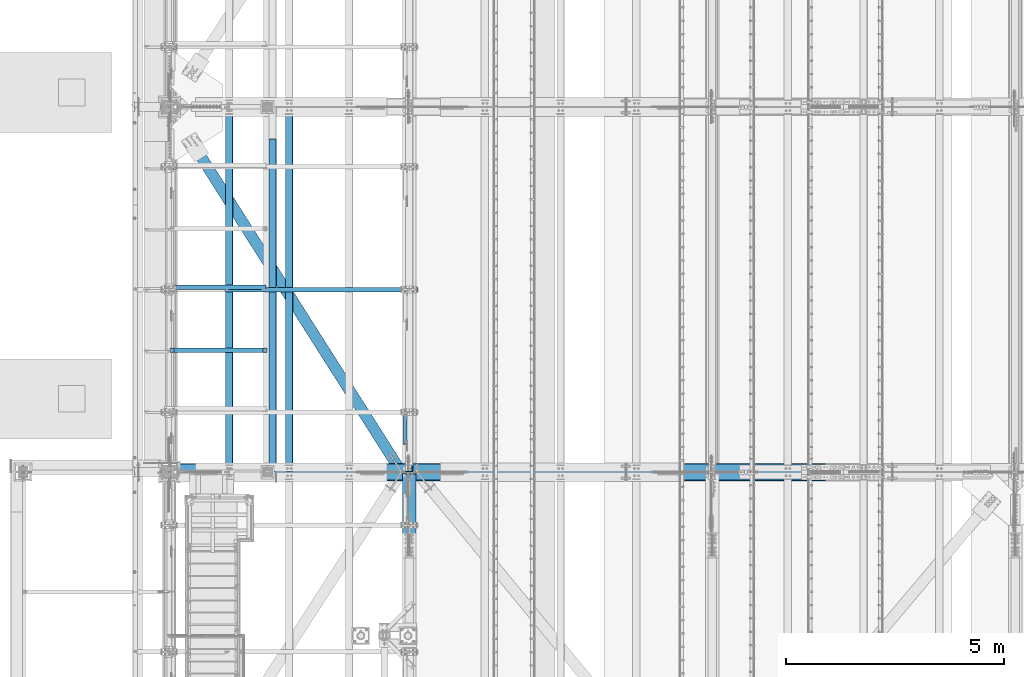
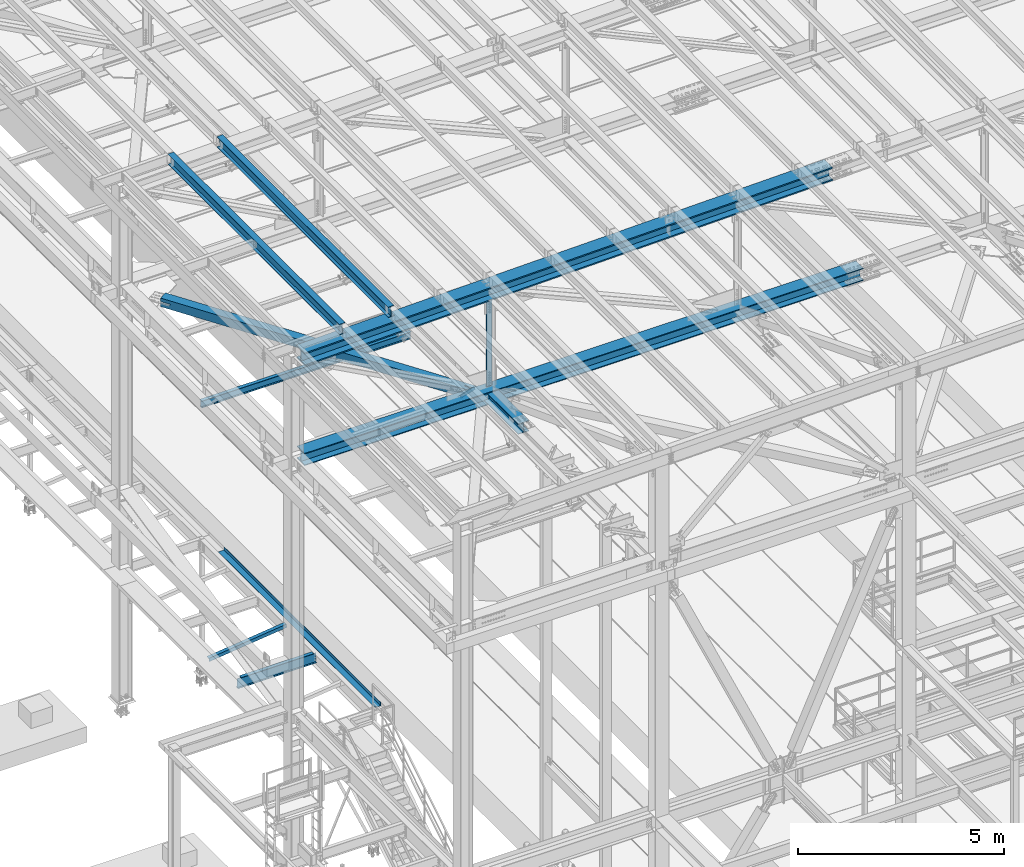
# One storey, part 1806 of 3843: 11 beams, 1 member, 11 elements without a shape of their own.
"""IFC2X3 building model written with IfcOpenShell, lengths in millimetres."""

from ifc_helpers import new_model, si_unit, frame, origin_with_axes, place, context, subcontext, project, spatial, faceted_brep, material, type_object, element, aggregate, save


model = new_model("IFC2X3")

# Units and contexts
model_context = context("Model", 3, precision=1e-05, world=origin_with_axes())
body_context = subcontext(model_context, "Body", "Model", "MODEL_VIEW")
ifc_project = project(units=[si_unit("LENGTHUNIT", "METRE", prefix="MILLI"), si_unit("AREAUNIT", "SQUARE_METRE"), si_unit("VOLUMEUNIT", "CUBIC_METRE"), si_unit("MASSUNIT", "GRAM", prefix="KILO"), si_unit("TIMEUNIT", "SECOND"), si_unit("PLANEANGLEUNIT", "RADIAN"), si_unit("SOLIDANGLEUNIT", "STERADIAN"), si_unit("THERMODYNAMICTEMPERATUREUNIT", "DEGREE_CELSIUS"), si_unit("LUMINOUSINTENSITYUNIT", "LUMEN")], contexts=[model_context])

# Site, building, storey
site_placement = place(None, origin_with_axes())
site = spatial("IfcSite", under=ifc_project, at=site_placement, CompositionType="ELEMENT")
building_placement = place(site_placement, origin_with_axes())
building = spatial("IfcBuilding", under=site, at=building_placement, Name="Undefined", CompositionType="ELEMENT")
storey_placement = place(building_placement, origin_with_axes())
storey = spatial("IfcBuildingStorey", under=building, at=storey_placement, Name="Undefined", CompositionType="ELEMENT", Elevation=0.0)

# Assembly, beam
assembly_1_placement = place(storey_placement, origin_with_axes())
assembly_1 = element("IfcElementAssembly", 1, at=assembly_1_placement, inside=storey, Name="ANGLE", AssemblyPlace="NOTDEFINED", PredefinedType="RIGID_FRAME")
ifc_material_1 = material(Name="STEEL/A572-50")
beam_type_1 = type_object("IfcBeamType", Name="L4X4X3/8", PredefinedType="NOTDEFINED")
beam_1_placement = place(assembly_1_placement, frame((38788.5093206542, 38077.874218, 33960.1419503901), z_axis=(0.0, 1.0, 0.0), x_axis=(-0.993268693078032, 0.0, -0.115833084009098)))
beam_1 = element("IfcBeam", 2, at=beam_1_placement, type_object=beam_type_1, material=ifc_material_1, Name="ANGLE", ObjectType="L4X4X3/8", context=body_context, shape_type="Brep", body=[
    faceted_brep([(0.0, 50.8000000000029, -50.8000000000029), (0.0, 50.8000000000029, 50.8000000000029), (2192.8104802954, 50.7999999940694, 50.8000000000029), (2192.8104802954, 50.7999999940694, -50.8000000000029), (0.0, 41.2750000000015, 50.8000000000029), (2192.81048029537, 41.2749999940788, 50.8000000000029), (0.0, 41.2749999999942, -41.2750000000015), (2192.81048029537, 41.2749999940788, -41.2750000000015), (0.0, -50.8000000000029, -41.2750000000015), (2192.81048029512, -50.8000000058528, -41.2750000000015), (0.0, -50.8000000000029, -50.8000000000029), (2192.81048029512, -50.8000000058528, -50.8000000000029)], [[[0, 1, 2, 3]], [[1, 4, 5, 2]], [[4, 6, 7, 5]], [[6, 8, 9, 7]], [[8, 10, 11, 9]], [[10, 0, 3, 11]], [[5, 7, 9, 11, 3, 2]], [[10, 8, 6, 4, 1, 0]]]),
])
aggregate(assembly_1, [beam_1])

assembly_2_placement = place(storey_placement, origin_with_axes())
assembly_2 = element("IfcElementAssembly", 3, at=assembly_2_placement, inside=storey, Name="BEAM", AssemblyPlace="NOTDEFINED", PredefinedType="RIGID_FRAME")
ifc_material_2 = material(Name="STEEL/A992")
beam_type_2 = type_object("IfcBeamType", Name="W12X26", PredefinedType="NOTDEFINED")
beam_2_placement = place(assembly_2_placement, frame((39315.909262284, 33845.2697323849, 45633.2759905987), z_axis=(-0.0211520981862632, -0.00148010699961742, 0.99977517373937), x_axis=(0.0, 0.999998904151063, 0.00148043800022374)))
beam_2 = element("IfcBeam", 4, at=beam_2_placement, type_object=beam_type_2, material=ifc_material_2, Name="BEAM", ObjectType="W12X26", context=body_context, shape_type="Brep", body=[
    faceted_brep([(12.6974689719063, 82.5500000000684, -155.575000000084), (12.7115269488204, 82.5499999999593, -146.050000000228), (8343.92065673555, 82.5500000005122, -146.050000026378), (8343.90655870306, 82.5500000005268, -155.575000026394), (12.7140125297374, 3.17500000011205, -146.050000000425), (8343.92314231647, 3.17500000066502, -146.050000026575), (13.1463521932747, 3.17499999986467, 146.050000000359), (8344.35548198001, 3.17500000041036, 146.049999974217), (13.1438666123577, 82.5499999997046, 146.050000000556), (8344.35299639909, 82.5500000002576, 146.049999974406), (13.157964644859, 82.5499999996973, 155.575000000586), (8344.3670944316, 82.5500000002503, 155.574999974437), (13.1631346531794, -82.5499999999738, 155.575000000172), (8344.37226443992, -82.5499999994208, 155.574999974022), (13.1490366206708, -82.5499999999665, 146.050000000148), (8344.35816640741, -82.5499999994136, 146.049999973999), (13.1465510397466, -3.17500000011933, 146.050000000345), (8344.35568082648, -3.17499999956635, 146.049999974195), (12.7142113762093, -3.17499999986467, -146.050000000439), (8343.92334116295, -3.17499999931169, -146.050000026589), (12.7166969571335, -82.5499999997119, -146.050000000636), (8343.92582674388, -82.5499999991589, -146.050000026778), (12.7025580552727, -82.54999999961, -155.575000000543), (8343.91172871137, -82.5499999991516, -155.575000026802)], [[[0, 1, 2, 3]], [[1, 4, 5, 2]], [[4, 6, 7, 5]], [[6, 8, 9, 7]], [[8, 10, 11, 9]], [[10, 12, 13, 11]], [[12, 14, 15, 13]], [[14, 16, 17, 15]], [[16, 18, 19, 17]], [[18, 20, 21, 19]], [[20, 22, 23, 21]], [[22, 0, 3, 23]], [[5, 7, 9, 11, 13, 15, 17, 19, 21, 23, 3, 2]], [[22, 20, 18, 16, 14, 12, 10, 8, 6, 4, 1, 0]]]),
])
aggregate(assembly_2, [beam_2])

assembly_3_placement = place(storey_placement, origin_with_axes())
assembly_3 = element("IfcElementAssembly", 5, at=assembly_3_placement, inside=storey, Name="BEAM", AssemblyPlace="NOTDEFINED", PredefinedType="RIGID_FRAME")
beam_3_placement = place(assembly_3_placement, frame((37944.3092622946, 33845.3818949881, 45603.5956322492), z_axis=(-0.0211520981049397, -0.000759152000093307, 0.999775981124772), x_axis=(0.0, 0.999999711715768, 0.000759320999784055)))
beam_3 = element("IfcBeam", 6, at=beam_3_placement, type_object=beam_type_2, material=ifc_material_2, Name="BEAM", ObjectType="W12X26", context=body_context, shape_type="Brep", body=[
    faceted_brep([(12.698677882734, 82.5500000001193, -155.575000000288), (12.7059087992311, 82.550000000112, -146.050000000258), (8343.90831061216, 82.5499999995445, -146.049999973598), (8343.9011105949, 82.5499999798194, -155.575000016506), (12.7071836598843, 3.17500000025029, -146.050000000352), (8343.90958547281, 3.17499999968277, -146.049999973678), (12.9289317657676, 3.17499999975553, 146.050000000454), (8344.1313335787, 3.174999999188, 146.05000002712), (12.9276569051217, 82.54999999961, 146.050000000534), (8344.13005871805, 82.5499999990425, 146.0500000272), (12.9348878216188, 82.5499999995955, 155.575000000557), (8344.13728963455, 82.5499999990352, 155.575000027224), (12.9375395317693, -82.550000000112, 155.57500000039), (8344.13994134469, -82.5500000006796, 155.575000027056), (12.9303086152722, -82.5500000000902, 146.050000000359), (8344.1327104282, -82.5500000006577, 146.050000027026), (12.929033754619, -3.17500000023574, 146.050000000447), (8344.13143556755, -3.17500000080327, 146.050000027106), (12.7072856487284, -3.17499999974098, -146.050000000352), (8343.90968746167, -3.1750000003085, -146.049999973686), (12.7085605093816, -82.5499999995955, -146.050000000432), (8343.91096232231, -82.550000000163, -146.049999973773), (12.7013295928846, -82.5499999995809, -155.575000000463), (8343.90373140582, -82.5500000001484, -155.574999973804)], [[[0, 1, 2, 3]], [[1, 4, 5, 2]], [[4, 6, 7, 5]], [[6, 8, 9, 7]], [[8, 10, 11, 9]], [[10, 12, 13, 11]], [[12, 14, 15, 13]], [[14, 16, 17, 15]], [[16, 18, 19, 17]], [[18, 20, 21, 19]], [[20, 22, 23, 21]], [[22, 0, 3, 23]], [[5, 7, 9, 11, 13, 15, 17, 19, 21, 23, 3, 2]], [[22, 20, 18, 16, 14, 12, 10, 8, 6, 4, 1, 0]]]),
])
aggregate(assembly_3, [beam_3])

assembly_4_placement = place(storey_placement, origin_with_axes())
assembly_4 = element("IfcElementAssembly", 7, at=assembly_4_placement, inside=storey, Name="BEAM", AssemblyPlace="NOTDEFINED", PredefinedType="RIGID_FRAME")
ifc_material_3 = material(Name="STEEL/A36")
beam_type_3 = type_object("IfcBeamType", PredefinedType="NOTDEFINED")
beam_4_placement = place(assembly_4_placement, frame((38858.825, 37661.85, 34039.175), z_axis=(0.0, -1.0, 0.0), x_axis=(1.0, 0.0, 0.0)))
beam_4 = element("IfcBeam", 8, at=beam_4_placement, type_object=beam_type_3, material=ifc_material_3, Name="BENT_PLATE", context=body_context, shape_type="Brep", body=[
    faceted_brep([(25.3999999999942, -3.17500000000291, 3752.84999999999), (25.3999999999942, 3.17500000000291, 3752.84999999999), (0.0, 3.17500000000291, 3752.84999999999), (0.0, -3.17500000000291, 3752.84999999999), (25.400000000016, -3.17500000000291, 3810.00000000001), (25.400000000016, 3.17500000000291, 3810.0), (165.100006103516, -3.17500000000291, -3810.0), (0.0, -3.17500000000291, -3810.0), (0.0, 3.17500000000291, -3810.0), (158.750005722046, 3.17500000000291, -3810.0), (158.749999999993, 98.4249996185172, -3810.0), (165.099999999999, 98.4249999999811, -3810.0), (158.750005722046, 3.17500000000291, 3810.0), (158.749999999993, 98.4249996185172, 3810.0), (165.099999999999, 98.4249999999811, 3810.0), (165.100006103516, -3.17500000000291, 3810.0)], [[[0, 1, 2, 3]], [[4, 5, 1, 0]], [[6, 7, 8, 9, 10, 11]], [[9, 12, 13, 10]], [[14, 11, 10, 13]], [[15, 6, 11, 14]], [[3, 7, 6, 15, 4, 0]], [[8, 7, 3, 2]], [[12, 9, 8, 2, 1, 5]], [[15, 14, 13, 12, 5, 4]]]),
])
aggregate(assembly_4, [beam_4])

# Assembly, member
assembly_5_placement = place(storey_placement, origin_with_axes())
assembly_5 = element("IfcElementAssembly", 9, at=assembly_5_placement, inside=storey, Name="ANGLE", AssemblyPlace="NOTDEFINED", PredefinedType="RIGID_FRAME")
member_type = type_object("IfcMemberType", Name="L3X3X1/4", PredefinedType="NOTDEFINED")
member_placement = place(assembly_5_placement, frame((41973.5, 34262.8635145216, 42254.6364854784), z_axis=(0.0, -0.707106781186548, -0.707106781186548), x_axis=(5.70000238222118e-08, 0.707106781186546, -0.707106781186546)))
member = element("IfcMember", 10, at=member_placement, type_object=member_type, material=ifc_material_1, Name="ANGLE", ObjectType="L3X3X1/4", context=body_context, shape_type="Brep", body=[
    faceted_brep([(1266.4928988076, -38.0999999999985, -31.7499999999272), (1266.4928988076, -38.0999999999985, -38.0999999999112), (1266.4928988076, 38.0999999999985, -38.0999999999112), (1266.49289880759, 38.0999999999985, 38.099999999904), (1266.49289880759, 31.75, 38.099999999904), (1266.4928988076, 31.75, -31.7499999999272), (275.8928988077, 31.75, 38.0999999998967), (275.892898807697, 31.75, -31.7499999999272), (275.892898807697, -38.0999999999985, -31.7499999999272), (275.8928988077, -38.0999999999985, -38.0999999999185), (275.8928988077, 38.0999999999985, -38.0999999999185), (275.8928988077, 38.0999999999985, 38.0999999998967)], [[[0, 1, 2, 3, 4, 5]], [[5, 4, 6, 7]], [[0, 5, 7, 8]], [[1, 0, 8, 9]], [[2, 1, 9, 10]], [[3, 2, 10, 11]], [[4, 3, 11, 6]], [[10, 9, 8, 7, 6, 11]]]),
])
aggregate(assembly_5, [member])

# Assembly, beam
assembly_6_placement = place(storey_placement, origin_with_axes())
assembly_6 = element("IfcElementAssembly", 11, at=assembly_6_placement, inside=storey, Name="BEAM", AssemblyPlace="NOTDEFINED", PredefinedType="RIGID_FRAME")
beam_type_4 = type_object("IfcBeamType", Name="W8X13", PredefinedType="NOTDEFINED")
beam_5_placement = place(assembly_6_placement, frame((36372.8, 38023.8, 41402.0), z_axis=(0.0, 0.0, 1.0), x_axis=(1.0, 0.0, 0.0)))
beam_5 = element("IfcBeam", 12, at=beam_5_placement, type_object=beam_type_4, material=ifc_material_2, Name="BEAM", ObjectType="W8X13", context=body_context, shape_type="Brep", body=[
    faceted_brep([(0.0, 50.7999999999993, -101.599999999999), (0.0, 50.7999999999993, -95.25), (5892.8, 50.7999999999993, -95.25), (5892.8, 50.7999999999993, -101.599999999999), (0.0, 3.17499999999927, -95.25), (5892.8, 3.17499999999927, -95.25), (-2.44140610448085e-05, 3.17500000000291, 95.2499999999927), (5892.8, 3.17499999999927, 95.25), (0.0, 50.7999999999993, 95.25), (5892.8, 50.7999999999993, 95.25), (0.0, 50.7999999999993, 101.599999999999), (5892.8, 50.7999999999993, 101.599999999999), (0.0, -50.7999999999993, 101.599999999999), (5892.8, -50.7999999999993, 101.599999999999), (0.0, -50.7999999999993, 95.25), (5892.8, -50.7999999999993, 95.25), (0.0, -3.17499999999927, 95.25), (5892.8, -3.17499999999927, 95.25), (0.0, -3.17499999999927, -95.25), (5892.8, -3.17499999999927, -95.25), (0.0, -50.7999999999993, -95.25), (5892.8, -50.7999999999993, -95.25), (0.0, -50.7999999999993, -101.599999999999), (5892.8, -50.7999999999993, -101.599999999999)], [[[0, 1, 2, 3]], [[1, 4, 5, 2]], [[4, 6, 7, 5]], [[6, 8, 9, 7]], [[8, 10, 11, 9]], [[10, 12, 13, 11]], [[12, 14, 15, 13]], [[14, 16, 17, 15]], [[16, 18, 19, 17]], [[18, 20, 21, 19]], [[20, 22, 23, 21]], [[22, 0, 3, 23]], [[5, 7, 9, 11, 13, 15, 17, 19, 21, 23, 3, 2]], [[22, 20, 18, 16, 14, 12, 10, 8, 6, 4, 1, 0]]]),
])
aggregate(assembly_6, [beam_5])

assembly_7_placement = place(storey_placement, origin_with_axes())
assembly_7 = element("IfcElementAssembly", 13, at=assembly_7_placement, inside=storey, Name="BEAM", AssemblyPlace="NOTDEFINED", PredefinedType="RIGID_FRAME")
beam_type_5 = type_object("IfcBeamType", Name="W12X79", PredefinedType="NOTDEFINED")
beam_6_placement = place(assembly_7_placement, frame((42062.4, 32169.0999999718, 42248.6593218951), z_axis=(0.0, -0.000321877000067616, 0.999999948197597), x_axis=(0.0, 0.999999948197597, 0.000321877000061539)))
beam_6 = element("IfcBeam", 14, at=beam_6_placement, type_object=beam_type_5, material=ifc_material_2, Name="BEAM", ObjectType="W12X79", context=body_context, shape_type="Brep", body=[
    faceted_brep([(1656.60692386963, -6.34999999999854, -131.762500000041), (1669.30692386962, 6.34999999999854, -119.062500000044), (1669.30692386961, 6.34999999999854, 119.062500000349), (1656.60692386937, -6.34999999999854, 131.762500000201), (1650.25692386956, -6.34999999999854, -138.11250000009), (1650.25692386956, -153.987500000003, -138.11250000009), (1631.20692386962, -153.987500000003, -157.162500000049), (1631.20692386962, 153.987500000003, -157.162500000049), (1650.25692386956, 153.987500000003, -138.11250000009), (1650.25692386956, 6.34999999999854, -138.11250000009), (6.34999999578577, -153.987500000003, 157.162499999627), (6.34999999578577, -153.987500000003, 138.112499999675), (1650.25692387025, -153.987500000003, 138.112499999232), (1631.20692386941, -153.987500000003, 157.162499999191), (6.34999999578577, 153.987500000003, 157.162499999627), (1631.20692386941, 153.987500000003, 157.162499999191), (6.34999999578577, 153.987500000003, 138.112499999675), (1650.25692387025, 153.987500000003, 138.112499999232), (6.34999999578577, 6.34999999999854, 138.112499999675), (1650.25692387025, 6.34999999999854, 138.112499999232), (6.34999999578577, -153.987500000003, -157.162499999562), (6.34999999578577, -153.987500000003, -138.11249999961), (6.34999999578577, -6.34999999999854, -138.11249999961), (6.34999999578577, -6.34999999999854, 138.112499999675), (6.34999999578577, 6.34999999999854, -138.11249999961), (6.34999999578577, 153.987500000003, -138.11249999961), (6.34999999578577, 153.987500000003, -157.162499999562), (1650.25692387025, -6.34999999999854, 138.112499999232)], [[[0, 1, 2, 3]], [[4, 5, 6, 7, 8, 9, 1, 0]], [[10, 11, 12, 13]], [[14, 10, 13, 15]], [[16, 14, 15, 17]], [[18, 16, 17, 19]], [[20, 21, 22, 23, 11, 10, 14, 16, 18, 24, 25, 26]], [[11, 23, 27, 12]], [[19, 17, 15, 13, 12, 27, 3, 2]], [[24, 18, 19, 2, 1, 9]], [[25, 24, 9, 8]], [[26, 25, 8, 7]], [[20, 26, 7, 6]], [[21, 20, 6, 5]], [[22, 21, 5, 4]], [[27, 23, 22, 4, 0, 3]]]),
])

assembly_8_placement = place(storey_placement, origin_with_axes())
assembly_8 = element("IfcElementAssembly", 15, at=assembly_8_placement, inside=storey, Name="BEAM", AssemblyPlace="NOTDEFINED", PredefinedType="RIGID_FRAME")
beam_type_6 = type_object("IfcBeamType", Name="W14X193", PredefinedType="NOTDEFINED")
beam_7_placement = place(assembly_8_placement, frame((36554.8646473075, 33845.5, 45221.0215623913), z_axis=(-0.0216342480057937, 0.0, 0.999765952267441), x_axis=(0.999765952267441, 0.0, 0.0216342480057898)))
beam_7 = element("IfcBeam", 16, at=beam_7_placement, type_object=beam_type_6, material=ifc_material_2, Name="BEAM", ObjectType="W14X193", context=body_context, shape_type="Brep", body=[
    faceted_brep([(213.776684537726, 200.025000000001, -196.85000000026), (214.566790013458, 200.025000000001, -160.337500000169), (15033.9642068568, 200.025000000001, -160.337499981455), (15033.9642068568, 200.025000000001, -196.849999981554), (214.566790013458, 11.1125000000029, -160.337500000169), (15033.9642068568, 11.1125000000029, -160.337499981455), (221.505977235109, 11.1125000000029, 160.337500000714), (15033.9642068568, 11.1125000000029, 160.337500019414), (221.505977235109, 200.025000000001, 160.337500000714), (15033.9642068568, 200.025000000001, 160.337500019414), (222.296082710847, 200.025000000001, 196.850000000813), (15033.9642068568, 200.025000000001, 196.850000019513), (222.296082710847, -200.025000000001, 196.850000000813), (15033.9642068568, -200.025000000001, 196.850000019513), (221.505977235109, -200.025000000001, 160.337500000714), (15033.9642068568, -200.025000000001, 160.337500019414), (221.505977235109, -11.1125000000029, 160.337500000714), (15033.9642068568, -11.1125000000029, 160.337500019414), (214.566790013458, -11.1125000000029, -160.337500000169), (15033.9642068568, -11.1125000000029, -160.337499981455), (214.566790013458, -200.025000000001, -160.337500000169), (15033.9642068568, -200.025000000001, -160.337499981455), (213.776684537726, -200.025000000001, -196.85000000026), (15033.9642068568, -200.025000000001, -196.849999981554)], [[[0, 1, 2, 3]], [[1, 4, 5, 2]], [[4, 6, 7, 5]], [[6, 8, 9, 7]], [[8, 10, 11, 9]], [[10, 12, 13, 11]], [[12, 14, 15, 13]], [[14, 16, 17, 15]], [[16, 18, 19, 17]], [[18, 20, 21, 19]], [[20, 22, 23, 21]], [[22, 0, 3, 23]], [[5, 7, 9, 11, 13, 15, 17, 19, 21, 23, 3, 2]], [[22, 20, 18, 16, 14, 12, 10, 8, 6, 4, 1, 0]]]),
])
aggregate(assembly_8, [beam_7])

# Beam
beam_type_7 = type_object("IfcBeamType", Name="W14X120", PredefinedType="NOTDEFINED")
beam_8_placement = place(assembly_7_placement, frame((36576.0, 33845.5, 42246.55), z_axis=(-0.00048281500021403, 0.0, 0.999999883444831), x_axis=(0.999999883444831, 0.0, 0.000482815000217081)))
beam_8 = element("IfcBeam", 17, at=beam_8_placement, type_object=beam_type_7, material=ifc_material_2, Name="BEAM", ObjectType="W14X120", context=body_context, shape_type="Brep", body=[
    faceted_brep([(196.772609585409, -185.737500000003, -160.337500000758), (196.761112551874, -185.737500000003, -184.150000000795), (15881.3518519562, -185.737500000003, -184.150000040754), (15881.3518519562, -185.737500000003, -160.337500040718), (196.772609585409, -7.14375000000291, -160.337500000758), (15881.3518519562, -7.14375000000291, -160.337500040718), (196.927436303646, -7.14375000000291, 160.337499999754), (15881.3518519562, -7.14375000000291, 160.337499959795), (196.927436303646, -185.737500000003, 160.337499999754), (15881.3518519562, -185.737500000003, 160.337499959795), (196.93893333718, -185.737500000003, 184.14999999979), (15881.3518519562, -185.737500000003, 184.149999959831), (196.93893333718, 185.737500000003, 184.14999999979), (15881.3518519562, 185.737500000003, 184.149999959831), (196.927436303646, 185.737500000003, 160.337499999754), (15881.3518519562, 185.737500000003, 160.337499959795), (196.927436303646, 7.14375000000291, 160.337499999754), (15881.3518519562, 7.14375000000291, 160.337499959795), (196.772609585409, 7.14375000000291, -160.337500000758), (15881.3518519562, 7.14375000000291, -160.337500040718), (196.772609585409, 185.737500000003, -160.337500000758), (15881.3518519562, 185.737500000003, -160.337500040718), (196.761112551874, 185.737500000003, -184.150000000795), (15881.3518519562, 185.737500000003, -184.150000040754)], [[[0, 1, 2, 3]], [[4, 0, 3, 5]], [[6, 4, 5, 7]], [[8, 6, 7, 9]], [[10, 8, 9, 11]], [[12, 10, 11, 13]], [[14, 12, 13, 15]], [[16, 14, 15, 17]], [[18, 16, 17, 19]], [[20, 18, 19, 21]], [[1, 0, 4, 6, 8, 10, 12, 14, 16, 18, 20, 22]], [[1, 22, 23, 2]], [[19, 17, 15, 13, 11, 9, 7, 5, 3, 2, 23, 21]], [[22, 20, 21, 23]]]),
])

aggregate(assembly_7, [beam_6, beam_8])

# Assembly, beam
assembly_9_placement = place(storey_placement, origin_with_axes())
assembly_9 = element("IfcElementAssembly", 18, at=assembly_9_placement, inside=storey, Name="ANGLE", AssemblyPlace="NOTDEFINED", PredefinedType="RIGID_FRAME")
beam_type_8 = type_object("IfcBeamType", Name="L6X6X1/2", PredefinedType="NOTDEFINED")
beam_9_placement = place(assembly_9_placement, frame((42062.4, 33931.2249999998, 45340.2008527698), z_axis=(-1.0, 0.0, 0.0), x_axis=(0.0, 0.0, -1.0)))
beam_9 = element("IfcBeam", 19, at=beam_9_placement, type_object=beam_type_8, material=ifc_material_1, Name="ANGLE", ObjectType="L6X6X1/2", context=body_context, shape_type="Brep", body=[
    faceted_brep([(223.225646543862, 76.1999999999971, -76.1999999999971), (223.225646543862, 76.1999999999971, 76.1999999999971), (2881.50254246687, 76.1999999999971, 76.1999999999971), (2881.50254246687, 76.1999999999971, -76.1999999999971), (223.225646543862, 63.5, 76.1999999999971), (2881.50254246687, 63.5, 76.1999999999971), (223.225646543862, 63.5, -63.5), (2881.50254246687, 63.5, -63.5), (223.225646543862, -76.1999999999971, -63.5), (2881.50254246687, -76.1999999999971, -63.5), (223.225646543862, -76.1999999999971, -76.1999999999971), (2881.50254246687, -76.1999999999971, -76.1999999999971)], [[[0, 1, 2, 3]], [[1, 4, 5, 2]], [[4, 6, 7, 5]], [[6, 8, 9, 7]], [[8, 10, 11, 9]], [[10, 0, 3, 11]], [[5, 7, 9, 11, 3, 2]], [[10, 8, 6, 4, 1, 0]]]),
])
aggregate(assembly_9, [beam_9])

assembly_10_placement = place(storey_placement, origin_with_axes())
assembly_10 = element("IfcElementAssembly", 20, at=assembly_10_placement, inside=storey, AssemblyPlace="NOTDEFINED", PredefinedType="RIGID_FRAME")
ifc_material_4 = material()
beam_type_9 = type_object("IfcBeamType", Name="HSS10X10X3/4", PredefinedType="NOTDEFINED")
beam_10_placement = place(assembly_10_placement, frame((36576.0, 42202.1, 42246.5500000009), z_axis=(0.844083796432185, 0.53621128727455, 0.0), x_axis=(0.536211309998039, -0.844083781996898, 0.0)))
beam_10 = element("IfcBeam", 21, at=beam_10_placement, type_object=beam_type_9, material=ifc_material_4, ObjectType="HSS10X10X3/4", context=body_context, shape_type="Brep", body=[
    faceted_brep([(9656.0334554301, -127.0, -14.2875066509878), (9656.0334554301, -107.949999999997, -14.2875066509878), (9403.62095610797, -107.949999999997, -14.2875136598741), (9403.62095610797, -127.0, -14.2875136598741), (9398.15336637764, -107.949999999997, -13.1999425975082), (9398.15336637764, -127.0, -13.1999425975082), (9393.51816756405, -107.949999999997, -10.1028019430596), (9393.51816756405, -127.0, -10.1028019430596), (9390.42102667221, -107.949999999997, -5.46760328808159), (9390.42102667221, -127.0, -5.46760328808159), (9389.33345532982, -107.949999999997, -1.43763463711366e-05), (9389.33345532982, -127.0, -1.43763463711366e-05), (9390.421026404, -107.949999999997, 5.46757532078482), (9390.421026404, -127.0, 5.46757532078482), (9393.51816704663, -107.949999999997, 10.1027741058715), (9393.51816704663, -127.0, 10.1027741058715), (9398.1533656731, -107.949999999997, 13.1999149858966), (9398.1533656731, -127.0, 13.1999149858966), (9403.62095531452, -107.949999999997, 14.2874863400939), (9403.62095531452, -127.0, 14.2874863400939), (9674.18596335511, -127.0, 14.2874938529858), (9674.18596335511, -107.949999999997, 14.2874938529858), (9656.0334554301, 107.949999999997, -14.2875066509878), (9656.0334554301, 127.0, -14.2875066509878), (9403.62095610797, 127.0, -14.2875136598741), (9403.62095610797, 107.949999999997, -14.2875136598741), (9398.15336637764, 127.0, -13.1999425975082), (9398.15336637764, 107.949999999997, -13.1999425975082), (9393.51816756405, 127.0, -10.1028019430596), (9393.51816756405, 107.949999999997, -10.1028019430596), (9390.42102667221, 127.0, -5.46760328808159), (9390.42102667221, 107.949999999997, -5.46760328808159), (9389.33345532982, 127.0, -1.43763463711366e-05), (9389.33345532982, 107.949999999997, -1.43763463711366e-05), (9390.421026404, 127.0, 5.46757532078482), (9390.421026404, 107.949999999997, 5.46757532078482), (9393.51816704663, 127.0, 10.1027741058715), (9393.51816704663, 107.949999999997, 10.1027741058715), (9398.1533656731, 127.0, 13.1999149858966), (9398.1533656731, 107.949999999997, 13.1999149858966), (9403.62095531452, 127.0, 14.2874863400939), (9403.62095531452, 107.949999999997, 14.2874863400939), (9674.18596335511, 107.949999999997, 14.2874938529858), (9674.18596335511, 127.0, 14.2874938529858), (1125.22804774128, 1.58750000000146, -107.949999997691), (1125.22804774128, 1.58750000000146, -126.999999997657), (1377.64054736225, 1.58750000000146, -126.999999997184), (1377.64054736222, 1.58750000000146, -107.949999997203), (1383.10813704813, 0.499928791716229, -126.99999999717), (1383.10813704809, 0.499928791716229, -107.949999997203), (1387.74333576815, -2.59721197552426, -126.999999997162), (1387.74333576811, -2.59721197552426, -107.949999997189), (1390.84047653538, -7.23241069557116, -126.999999997155), (1390.84047653534, -7.23241069557116, -107.949999997189), (1391.92804774365, -12.6999996185259, -126.999999997155), (1391.92804774362, -12.6999996185259, -107.949999997181), (1390.84047653538, -18.167589304423, -126.999999997155), (1390.84047653534, -18.167589304423, -107.949999997189), (1387.74333576815, -22.8027880244699, -126.999999997162), (1387.74333576811, -22.8027880244699, -107.949999997189), (1383.10813704813, -25.8999287917104, -126.99999999717), (1383.10813704809, -25.8999287917104, -107.949999997203), (1377.64054736225, -26.9874999999956, -126.999999997184), (1377.64054736222, -26.9874999999956, -107.949999997203), (1125.22804774128, -26.9874999999956, -126.999999997657), (1125.22804774128, -26.9874999999956, -107.949999997691), (9596.53357362878, -107.949999999997, -107.949999981545), (1125.22804774128, -107.949999999997, -107.949999997691), (1125.22804774129, -107.949999999997, 107.950000001991), (9733.68585330987, -107.949999999997, 107.950000018391), (1125.22804774128, 107.949999999997, -107.949999997691), (9596.53357362878, 107.949999999997, -107.949999981545), (1383.10813704764, -25.8999287917104, 127.000000002452), (1383.10813704767, -25.8999287917104, 107.950000002485), (1377.6405473618, -26.9874999999956, 107.950000002471), (1377.64054736176, -26.9874999999956, 127.000000002437), (1387.74333576767, -22.8027880244699, 127.000000002459), (1387.7433357677, -22.8027880244699, 107.950000002485), (1390.8404765349, -18.167589304423, 127.000000002467), (1390.84047653493, -18.167589304423, 107.9500000025), (1391.92804774317, -12.6999996185259, 127.000000002474), (1391.92804774321, -12.6999996185259, 107.9500000025), (1390.8404765349, -7.23241069557116, 127.000000002467), (1390.84047653493, -7.23241069557116, 107.9500000025), (1387.74333576767, -2.59721197552426, 127.000000002459), (1387.7433357677, -2.59721197552426, 107.950000002485), (1383.10813704764, 0.499928791716229, 127.000000002452), (1383.10813704767, 0.499928791716229, 107.950000002485), (1377.64054736176, 1.58750000000146, 127.000000002437), (1377.6405473618, 1.58750000000146, 107.950000002471), (1125.22804774128, 1.58750000000146, 127.000000001965), (1125.22804774129, 1.58750000000146, 107.950000001991), (1125.22804774128, 127.0, 127.000000001965), (1125.22804774128, 127.0, -126.999999997657), (1125.22804774129, 107.949999999997, 107.950000001991), (1125.22804774129, -26.9874999999956, 107.950000001991), (9733.68585330987, 107.949999999997, 107.950000018391), (1125.22804774128, -26.9874999999956, 127.000000001965), (1125.22804774128, -127.0, -126.999999997657), (1125.22804774128, -127.0, 127.000000001965), (9745.78752504644, -127.0, 127.000000018394), (9745.78752504644, 127.0, 127.000000018394), (9584.43190189222, 127.0, -126.999999981541), (9584.43190189222, -127.0, -126.999999981541)], [[[0, 1, 2, 3]], [[3, 2, 4, 5]], [[5, 4, 6, 7]], [[7, 6, 8, 9]], [[9, 8, 10, 11]], [[11, 10, 12, 13]], [[13, 12, 14, 15]], [[15, 14, 16, 17]], [[17, 16, 18, 19]], [[20, 19, 18, 21]], [[22, 23, 24, 25]], [[25, 24, 26, 27]], [[27, 26, 28, 29]], [[29, 28, 30, 31]], [[31, 30, 32, 33]], [[33, 32, 34, 35]], [[35, 34, 36, 37]], [[37, 36, 38, 39]], [[39, 38, 40, 41]], [[42, 41, 40, 43]], [[44, 45, 46, 47]], [[47, 46, 48, 49]], [[49, 48, 50, 51]], [[51, 50, 52, 53]], [[53, 52, 54, 55]], [[55, 54, 56, 57]], [[57, 56, 58, 59]], [[59, 58, 60, 61]], [[61, 60, 62, 63]], [[63, 62, 64, 65]], [[16, 14, 12, 10, 8, 6, 4, 2, 1, 66, 67, 68, 69, 21, 18]], [[70, 44, 47, 49, 51, 53, 55, 57, 59, 61, 63, 65, 67, 66, 71]], [[72, 73, 74, 75]], [[76, 77, 73, 72]], [[78, 79, 77, 76]], [[80, 81, 79, 78]], [[82, 83, 81, 80]], [[84, 85, 83, 82]], [[86, 87, 85, 84]], [[88, 89, 87, 86]], [[90, 91, 89, 88]], [[92, 93, 45, 44, 70, 94, 91, 90]], [[68, 95, 74, 73, 77, 79, 81, 83, 85, 87, 89, 91, 94, 96, 69]], [[75, 74, 95, 97]], [[68, 67, 65, 64, 98, 99, 97, 95]], [[92, 90, 88, 86, 84, 82, 80, 78, 76, 72, 75, 97, 99, 100, 101]], [[69, 96, 42, 43, 101, 100, 20, 21]], [[38, 36, 34, 32, 30, 28, 26, 24, 23, 102, 93, 92, 101, 43, 40]], [[98, 64, 62, 60, 58, 56, 54, 52, 50, 48, 46, 45, 93, 102, 103]], [[100, 99, 98, 103, 0, 3, 5, 7, 9, 11, 13, 15, 17, 19, 20]], [[103, 102, 23, 22, 71, 66, 1, 0]], [[96, 94, 70, 71, 22, 25, 27, 29, 31, 33, 35, 37, 39, 41, 42]]]),
])
aggregate(assembly_10, [beam_10])

assembly_11_placement = place(storey_placement, origin_with_axes())
assembly_11 = element("IfcElementAssembly", 22, at=assembly_11_placement, inside=storey, Name="BEAM", AssemblyPlace="NOTDEFINED", PredefinedType="RIGID_FRAME")
beam_type_10 = type_object("IfcBeamType", Name="W12X14", PredefinedType="NOTDEFINED")
beam_11_placement = place(assembly_11_placement, frame((36576.0, 36631.165624, 33885.1875), z_axis=(0.0, 0.0, 1.0), x_axis=(1.0, 0.0, 0.0)))
beam_11 = element("IfcBeam", 23, at=beam_11_placement, type_object=beam_type_10, material=ifc_material_2, Name="BEAM", ObjectType="W12X14", context=body_context, shape_type="Brep", body=[
    faceted_brep([(92.8687501907334, -2.38125000000582, 125.412499999991), (92.8687501907334, 2.38125000000582, 125.412499999991), (16.6687499999971, 2.38125000000582, 125.412499999991), (16.6687499999971, -2.38125000000582, 125.412499999991), (97.7288297087798, -2.38125000000582, 126.379229922582), (97.7288297087798, 2.38125000000582, 126.379229922582), (101.849006176933, -2.38125000000582, 129.132243823056), (101.849006176933, 2.38125000000582, 129.132243823056), (104.602020077407, -2.38125000000582, 133.25242029121), (104.602020077407, 2.38125000000582, 133.25242029121), (105.568749999999, -2.38125000000582, 138.112499809256), (105.568749999999, 2.38125000000582, 138.112499809256), (105.568749999999, -50.8000000000029, 150.812499810811), (105.568749999999, 50.8000000000029, 150.8125), (105.568749999999, 50.8000000000029, 144.462500000001), (105.568749999999, 2.38125000000582, 144.462500000001), (105.568749999999, -2.38125000000582, 144.462500000001), (105.568749999999, -50.8000000000029, 144.462500000001), (16.6687499999971, -2.38125000000582, -144.462500000001), (16.6687499999971, -50.7999999999993, -144.462500000001), (2228.05625, -50.8000000000029, -144.462500000001), (2228.05625, -2.38125000000582, -144.462500000001), (16.6687499999971, -50.8000000000029, -150.8125), (2228.05625, -50.8000000000029, -150.8125), (16.6687499999971, 50.8000000000029, -150.8125), (2228.05625, 50.8000000000029, -150.8125), (16.6687499999971, 50.7999999999993, -144.462500000001), (2228.05625, 50.8000000000029, -144.462500000001), (16.6687499999971, 2.38125000000582, -144.462500000001), (2228.05625, 2.38125000000582, -144.462500000001), (2228.05625, 2.38125000000582, -117.887499999997), (2228.05625, 2.38125000000582, 112.712500000001), (2228.05625, 2.38125000000582, 125.412499999991), (2228.05625, -2.38125000000582, 125.412499999991), (2151.85624980927, 2.38125000000582, 125.412499999991), (2151.85624980927, -2.38125000000582, 125.412499999991), (2146.99617029122, 2.38125000000582, 126.379229922582), (2146.99617029122, -2.38125000000582, 126.379229922582), (2142.87599382307, 2.38125000000582, 129.132243823056), (2142.87599382307, -2.38125000000582, 129.132243823056), (2140.12297992259, 2.38125000000582, 133.25242029121), (2140.12297992259, -2.38125000000582, 133.25242029121), (2139.15625, 2.38125000000582, 138.112499809256), (2139.15625, -2.38125000000582, 138.112499809256), (2139.15625, -50.8000000000029, 150.8125), (2139.15625, -50.8000000000029, 144.462500000001), (2139.15625, -2.38125000000582, 144.462500000001), (2139.15625, 2.38125000000582, 144.462500000001), (2139.15625, 50.8000000000029, 144.462500000001), (2139.15625, 50.8000000000029, 150.8125), (16.6687499999971, 2.38125000000582, 112.712500000001), (16.6687499999971, 2.38125000000582, -117.887499999997)], [[[0, 1, 2, 3]], [[4, 5, 1, 0]], [[6, 7, 5, 4]], [[8, 9, 7, 6]], [[10, 11, 9, 8]], [[12, 13, 14, 15, 11, 10, 16, 17]], [[18, 19, 20, 21]], [[19, 22, 23, 20]], [[22, 24, 25, 23]], [[24, 26, 27, 25]], [[26, 28, 29, 27]], [[21, 20, 23, 25, 27, 29, 30, 31, 32, 33]], [[33, 32, 34, 35]], [[35, 34, 36, 37]], [[37, 36, 38, 39]], [[39, 38, 40, 41]], [[41, 40, 42, 43]], [[44, 45, 46, 43, 42, 47, 48, 49]], [[45, 44, 12, 17]], [[46, 45, 17, 16]], [[8, 6, 4, 0, 3, 18, 21, 33, 35, 37, 39, 41, 43, 46, 16, 10]], [[50, 51, 28, 26, 24, 22, 19, 18, 3, 2]], [[47, 42, 40, 38, 36, 34, 32, 31, 30, 29, 28, 51, 50, 2, 1, 5, 7, 9, 11, 15]], [[48, 47, 15, 14]], [[49, 48, 14, 13]], [[44, 49, 13, 12]]]),
])
aggregate(assembly_11, [beam_11])

save(model, "model.ifc")
